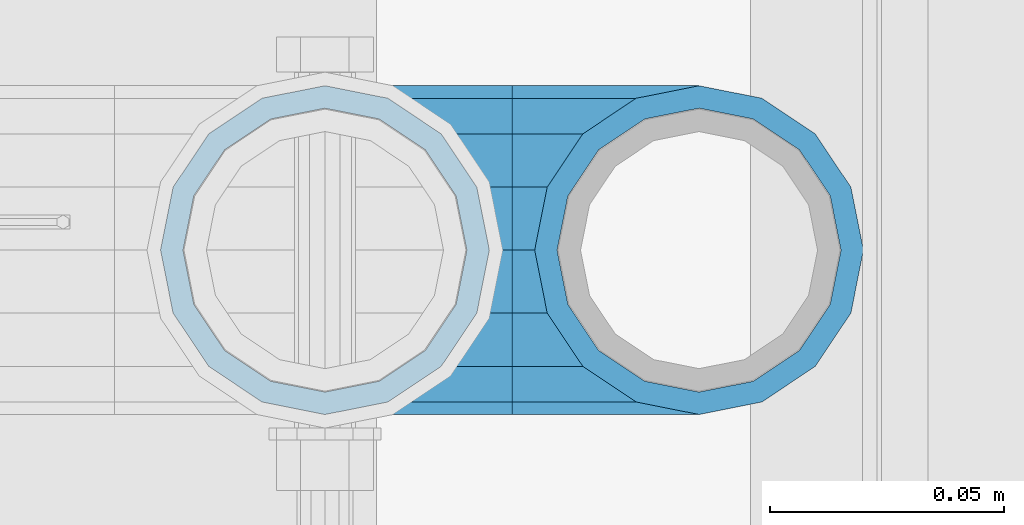
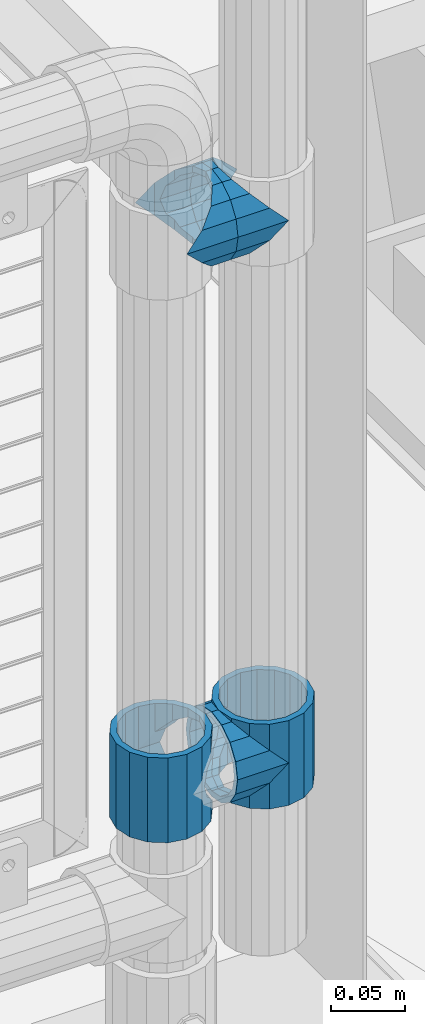
# One storey, part 167 of 242: 5 beams.
"""IFC2X3 building model written with IfcOpenShell, lengths in millimetres."""

from ifc_helpers import new_model, si_unit, frame, origin_with_axes, place, context, subcontext, project, spatial, faceted_brep, material, type_object, element, save


model = new_model("IFC2X3")

# Units and contexts
model_context = context("Model", 3, precision=1e-05, world=origin_with_axes())
body_context = subcontext(model_context, "Body", "Model", "MODEL_VIEW")
ifc_project = project(units=[si_unit("LENGTHUNIT", "METRE", prefix="MILLI"), si_unit("AREAUNIT", "SQUARE_METRE"), si_unit("VOLUMEUNIT", "CUBIC_METRE"), si_unit("MASSUNIT", "GRAM", prefix="KILO"), si_unit("TIMEUNIT", "SECOND"), si_unit("PLANEANGLEUNIT", "RADIAN"), si_unit("SOLIDANGLEUNIT", "STERADIAN"), si_unit("THERMODYNAMICTEMPERATUREUNIT", "DEGREE_CELSIUS"), si_unit("LUMINOUSINTENSITYUNIT", "LUMEN")], contexts=[model_context])

# Site, building, storey
site_placement = place(None, origin_with_axes())
site = spatial("IfcSite", under=ifc_project, at=site_placement, CompositionType="ELEMENT")
building_placement = place(site_placement, origin_with_axes())
building = spatial("IfcBuilding", under=site, at=building_placement, Name="Standard", CompositionType="ELEMENT")
storey_placement = place(building_placement, origin_with_axes())
storey = spatial("IfcBuildingStorey", under=building, at=storey_placement, Name="Undefined", CompositionType="ELEMENT", Elevation=0.0)

# Beams
ifc_material = material(Name="Misc_Undefined")
beam_type = type_object("IfcBeamType", PredefinedType="NOTDEFINED")
beam_1_placement = place(storey_placement, frame((-22576.0, -19335.5, 398.670000000001), z_axis=(0.0, 1.0, 0.0), x_axis=(-1.0, 0.0, 0.0)))
element("IfcBeam", 1, at=beam_1_placement, inside=storey, type_object=beam_type, material=ifc_material, context=body_context, shape_type="Brep", body=[
    faceted_brep([(0.0, 0.0, -35.1500000000015), (13.4513226476338, -13.4513226476329, -32.4743655677703), (13.4513226476338, 13.4513226476329, -32.4743655677703), (32.4743655677739, -26.8123795176754, 13.4513226476338), (32.4743655677739, -32.4743655677717, 13.4513226476338), (24.8548033587067, -24.8548033587072, 24.8548033587067), (24.8548033587067, -16.3810424080019, 24.8548033587067), (27.1226768591077, -21.4606908090117, 21.46069080901), (35.1500000000015, -30.35, 0.0), (35.1500000000015, -35.15, 0.0), (32.8397438117172, -28.0397438117175, 11.614442172282), (32.8397438117099, -28.0397438117175, -11.614442172282), (32.4743655677739, -26.8123795176754, -13.4513226476338), (32.4743655677739, -32.4743655677717, -13.4513226476338), (27.122676859115, -21.4606908090117, -21.46069080901), (24.8548033587067, -16.3810424080019, -24.8548033587067), (24.8548033587067, -24.8548033587072, -24.8548033587067), (20.0882031229849, -11.6144421722805, -28.0397438117179), (16.6306603983758, 0.0, -30.3499999999985), (20.0882031229849, 11.6144421722805, -28.0397438117179), (24.8548033587067, 16.3810424079986, -24.8548033587067), (24.8548033587067, 24.8548033587072, -24.8548033587067), (27.122676859115, 21.4606908090117, -21.46069080901), (32.4743655677739, 26.8123795176776, -13.4513226476338), (32.4743655677739, 32.4743655677717, -13.4513226476338), (32.8397438117099, 28.0397438117175, -11.614442172282), (35.1500000000015, 30.35, 0.0), (35.1500000000015, 35.1499999999996, 0.0), (32.8397438117172, 28.0397438117175, 11.614442172282), (32.4743655677739, 26.8123795176754, 13.4513226476338), (32.4743655677739, 32.4743655677717, 13.4513226476338), (27.1226768591077, 21.4606908090117, 21.46069080901), (24.8548033587067, 16.3810424080019, 24.8548033587067), (24.8548033587067, 24.8548033587072, 24.8548033587067), (13.4513226476338, 13.4513226476329, 32.4743655677703), (13.4513226476338, -13.4513226476329, 32.4743655677703), (0.0, 0.0, 35.1500000000015), (20.0882031229849, 11.6144421722805, 28.0397438117179), (16.6306603983685, 0.0, 30.3499999999985), (20.0882031229849, -11.6144421722805, 28.0397438117179), (40.1500000000015, -35.15, 0.0), (40.1500000000015, -32.4743655677717, 13.4513226476338), (40.1500000000015, -24.8548033587072, 24.8548033587067), (40.1500000000015, -13.4513226476329, 32.4743655677703), (40.1500000000015, 0.0, 35.1500000000015), (40.1500000000015, -24.8548033587072, -24.8548033587067), (40.1500000000015, -32.4743655677717, -13.4513226476338), (40.1500000000015, -13.4513226476329, -32.4743655677703), (40.1500000000015, 0.0, -35.1500000000015), (40.1500000000015, 13.4513226476329, -32.4743655677703), (40.1500000000015, 24.8548033587072, -24.8548033587067), (40.1500000000015, 32.4743655677717, -13.4513226476338), (40.1500000000015, 35.15, 0.0), (40.1500000000015, 32.4743655677717, 13.4513226476338), (40.1500000000015, 24.8548033587072, 24.8548033587067), (40.1500000000015, 13.4513226476329, 32.4743655677703), (40.1500000000015, -21.4606908090117, 21.46069080901), (40.1500000000015, -11.6144421722805, 28.0397438117179), (40.1500000000015, 0.0, 30.3499999999985), (40.1500000000015, 11.6144421722805, 28.0397438117179), (40.1500000000015, 21.4606908090117, 21.46069080901), (40.1500000000015, 28.0397438117175, 11.614442172282), (40.1500000000015, 30.35, 0.0), (40.1500000000015, 28.0397438117175, -11.614442172282), (40.1500000000015, 21.4606908090117, -21.46069080901), (40.1500000000015, 11.6144421722805, -28.0397438117179), (40.1500000000015, 0.0, -30.3499999999985), (40.1500000000015, -11.6144421722805, -28.0397438117179), (40.1500000000015, -21.4606908090117, -21.46069080901), (40.1500000000015, -28.0397438117175, -11.614442172282), (40.1500000000015, -30.35, 0.0), (40.1500000000015, -28.0397438117175, 11.614442172282)], [[[0, 1, 2]], [[3, 4, 5, 6, 7]], [[8, 9, 4, 3, 10]], [[11, 12, 13, 9, 8]], [[14, 15, 16, 13, 12]], [[2, 1, 16, 15, 17, 18, 19, 20, 21]], [[21, 20, 22, 23, 24]], [[24, 23, 25, 26, 27]], [[27, 26, 28, 29, 30]], [[30, 29, 31, 32, 33]], [[34, 35, 36]], [[33, 32, 37, 38, 39, 6, 5, 35, 34]], [[40, 41, 4, 9]], [[41, 42, 5, 4]], [[42, 43, 35, 5]], [[43, 44, 36, 35]], [[45, 46, 13, 16]], [[47, 45, 16, 1]], [[48, 47, 1, 0]], [[49, 48, 0, 2]], [[50, 49, 2, 21]], [[51, 50, 21, 24]], [[52, 51, 24, 27]], [[53, 52, 27, 30]], [[54, 53, 30, 33]], [[55, 54, 33, 34]], [[44, 55, 34, 36]], [[46, 40, 9, 13]], [[45, 47, 48, 49, 50, 51, 52, 53, 54, 55, 44, 43, 42, 41, 40, 46], [56, 57, 58, 59, 60, 61, 62, 63, 64, 65, 66, 67, 68, 69, 70, 71]], [[59, 58, 38, 37]], [[60, 59, 37, 32, 31]], [[61, 60, 31, 29, 28]], [[62, 61, 28, 26]], [[63, 62, 26, 25]], [[22, 64, 63, 25, 23]], [[19, 65, 64, 22, 20]], [[66, 65, 19, 18]], [[67, 66, 18, 17]], [[68, 67, 17, 15, 14]], [[69, 68, 14, 12, 11]], [[70, 69, 11, 8]], [[71, 70, 8, 10]], [[7, 56, 71, 10, 3]], [[39, 57, 56, 7, 6]], [[58, 57, 39, 38]]]),
])
beam_2_placement = place(storey_placement, frame((-22656.0, -19335.5, 433.82), z_axis=(-1.0, 0.0, 0.0), x_axis=(0.0, 0.0, -1.0)))
element("IfcBeam", 2, at=beam_2_placement, inside=storey, type_object=beam_type, material=ifc_material, context=body_context, shape_type="Brep", body=[
    faceted_brep([(7.11025618828211, -11.614442172282, -32.8397438117172), (7.11025618828211, -11.614442172282, -28.0397438117143), (13.6893091909879, -21.46069080901, -21.4606908090136), (13.6893091909879, -21.46069080901, -27.1226768591077), (8.33762048232484, -13.4513226476338, -32.4743655677739), (23.5355578277191, -28.0397438117179, -11.6144421722784), (23.5355578277191, -28.0397438117179, -20.0882031229921), (18.7689575919975, -24.8548033587067, -24.8548033587067), (35.1500000000015, -30.35, 0.0), (35.1499999999996, -30.3499999999985, -16.6306603983758), (46.7644421722801, -28.0397438117179, -11.6144421722784), (46.7644421722801, -28.0397438117179, -20.0882031229921), (51.5310424079973, -24.8548033587067, -24.8548033587067), (56.6106908090114, -21.46069080901, -21.4606908090136), (56.6106908090114, -21.46069080901, -27.1226768591077), (61.9623795176767, -13.4513226476338, -32.4743655677739), (63.1897438117172, -11.614442172282, -28.0397438117143), (63.1897438117172, -11.614442172282, -32.8397438117172), (65.4999999999997, 0.0, -30.3499999999985), (65.4999999999997, 0.0, -35.1500000000015), (63.1897438117172, 11.614442172282, -28.0397438117143), (63.1897438117172, 11.614442172282, -32.8397438117245), (56.6106908090114, 21.46069080901, -21.4606908090136), (56.6106908090114, 21.46069080901, -27.1226768591077), (61.9623795176744, 13.4513226476338, -32.4743655677739), (46.7644421722801, 28.0397438117179, -11.6144421722784), (46.7644421722801, 28.0397438117179, -20.0882031229849), (51.5310424080006, 24.8548033587067, -24.8548033587067), (35.1500000000015, 30.35, 0.0), (35.1499999999996, 30.3499999999985, -16.6306603983685), (23.5355578277192, 28.0397438117179, -11.6144421722784), (23.5355578277192, 28.0397438117179, -20.0882031229849), (18.7689575919987, 24.8548033587067, -24.8548033587067), (13.6893091909879, 21.46069080901, -21.4606908090136), (13.6893091909879, 21.46069080901, -27.1226768591077), (8.33762048232262, 13.4513226476338, -32.4743655677739), (7.11025618828211, 11.614442172282, -28.0397438117143), (7.11025618828211, 11.614442172282, -32.8397438117245), (4.79999999999961, 0.0, -30.3499999999985), (4.79999999999961, 0.0, -35.1500000000015), (0.0, 21.46069080901, 21.4606908090136), (0.0, 28.0397438117179, 11.6144421722784), (70.2999999999993, 28.0397438117179, 11.6144421722784), (70.2999999999993, 21.46069080901, 21.4606908090136), (0.0, 11.614442172282, 28.0397438117143), (70.2999999999993, 11.614442172282, 28.0397438117143), (0.0, 0.0, 30.3499999999985), (70.2999999999993, 0.0, 30.3499999999985), (0.0, -11.614442172282, 28.0397438117143), (70.2999999999993, -11.614442172282, 28.0397438117143), (0.0, -21.46069080901, 21.4606908090136), (70.2999999999993, -21.46069080901, 21.4606908090136), (0.0, -28.0397438117179, 11.6144421722784), (70.2999999999993, -28.0397438117179, 11.6144421722784), (0.0, -24.8548033587067, -24.8548033587067), (0.0, -13.4513226476338, -32.4743655677739), (0.0, 0.0, -35.1500000000015), (0.0, -32.4743655677703, 13.4513226476338), (0.0, -35.1500000000015, 0.0), (70.2999999999993, -35.1500000000015, 0.0), (70.2999999999993, -32.4743655677703, 13.4513226476338), (0.0, -24.8548033587067, 24.8548033587067), (70.2999999999993, -24.8548033587067, 24.8548033587067), (0.0, -13.4513226476338, 32.4743655677739), (70.2999999999993, -13.4513226476338, 32.4743655677739), (0.0, 0.0, 35.1500000000015), (70.2999999999993, 0.0, 35.1500000000015), (0.0, 13.4513226476338, 32.4743655677739), (70.2999999999993, 13.4513226476338, 32.4743655677739), (0.0, 24.8548033587067, 24.8548033587067), (70.2999999999993, 24.8548033587067, 24.8548033587067), (0.0, 32.4743655677703, 13.4513226476338), (70.2999999999993, 32.4743655677703, 13.4513226476338), (0.0, 35.1500000000015, 0.0), (70.2999999999993, 35.1500000000015, 0.0), (0.0, 32.4743655677703, -13.4513226476338), (70.2999999999993, 32.4743655677703, -13.4513226476338), (70.2999999999993, -13.4513226476338, -32.4743655677739), (70.2999999999993, -24.8548033587067, -24.8548033587067), (70.2999999999993, 0.0, -35.1500000000015), (70.2999999999993, 13.4513226476338, -32.4743655677739), (70.2999999999993, 24.8548033587067, -24.8548033587067), (0.0, 24.8548033587067, -24.8548033587067), (0.0, 13.4513226476338, -32.4743655677739), (70.2999999999993, -32.4743655677703, -13.4513226476338), (0.0, -32.4743655677703, -13.4513226476338), (0.0, -28.0397438117179, -11.6144421722784), (0.0, -21.46069080901, -21.4606908090136), (0.0, -11.614442172282, -28.0397438117143), (0.0, 0.0, -30.3499999999985), (0.0, 11.614442172282, -28.0397438117143), (0.0, 21.46069080901, -21.4606908090136), (0.0, 28.0397438117179, -11.6144421722784), (0.0, 30.3499999999985, 0.0), (0.0, -30.3499999999985, 0.0), (70.2999999999993, 30.3499999999985, 0.0), (70.2999999999993, 28.0397438117179, -11.6144421722784), (70.2999999999993, 21.46069080901, -21.4606908090136), (70.2999999999993, 11.614442172282, -28.0397438117143), (70.2999999999993, 0.0, -30.3499999999985), (70.2999999999993, -11.614442172282, -28.0397438117143), (70.2999999999993, -21.46069080901, -21.4606908090136), (70.2999999999993, -28.0397438117179, -11.6144421722784), (70.2999999999993, -30.3499999999985, 0.0)], [[[0, 1, 2, 3, 4]], [[3, 2, 5, 6, 7]], [[6, 5, 8, 9]], [[9, 8, 10, 11]], [[12, 11, 10, 13, 14]], [[15, 14, 13, 16, 17]], [[17, 16, 18, 19]], [[19, 18, 20, 21]], [[21, 20, 22, 23, 24]], [[23, 22, 25, 26, 27]], [[26, 25, 28, 29]], [[29, 28, 30, 31]], [[32, 31, 30, 33, 34]], [[35, 34, 33, 36, 37]], [[37, 36, 38, 39]], [[39, 38, 1, 0]], [[40, 41, 42, 43]], [[44, 40, 43, 45]], [[46, 44, 45, 47]], [[48, 46, 47, 49]], [[50, 48, 49, 51]], [[52, 50, 51, 53]], [[7, 54, 55, 4, 3]], [[4, 55, 56, 39, 0]], [[57, 58, 59, 60]], [[61, 57, 60, 62]], [[63, 61, 62, 64]], [[65, 63, 64, 66]], [[67, 65, 66, 68]], [[69, 67, 68, 70]], [[71, 69, 70, 72]], [[73, 71, 72, 74]], [[75, 73, 74, 76]], [[77, 78, 12, 14, 15]], [[79, 77, 15, 17, 19]], [[24, 80, 79, 19, 21]], [[27, 81, 80, 24, 23]], [[82, 75, 76, 81, 27, 26, 29, 31, 32]], [[83, 82, 32, 34, 35]], [[56, 83, 35, 37, 39]], [[9, 11, 12, 78, 84, 85, 54, 7, 6]], [[58, 85, 84, 59]], [[57, 61, 63, 65, 67, 69, 71, 73, 75, 82, 83, 56, 55, 54, 85, 58], [86, 87, 88, 89, 90, 91, 92, 93, 41, 40, 44, 46, 48, 50, 52, 94]], [[90, 89, 38, 36]], [[91, 90, 36, 33]], [[92, 91, 33, 30]], [[93, 92, 30, 28]], [[41, 93, 28, 95, 42]], [[96, 95, 28, 25]], [[97, 96, 25, 22]], [[98, 97, 22, 20]], [[99, 98, 20, 18]], [[100, 99, 18, 16]], [[101, 100, 16, 13]], [[102, 101, 13, 10]], [[103, 102, 10, 8]], [[78, 77, 79, 80, 81, 76, 74, 72, 70, 68, 66, 64, 62, 60, 59, 84], [51, 49, 47, 45, 43, 42, 95, 96, 97, 98, 99, 100, 101, 102, 103, 53]], [[8, 94, 52, 53, 103]], [[86, 94, 8, 5]], [[87, 86, 5, 2]], [[88, 87, 2, 1]], [[89, 88, 1, 38]]]),
])
beam_3_placement = place(storey_placement, frame((-22576.0, -19335.5, 433.82), z_axis=(1.0, 0.0, 0.0), x_axis=(0.0, 0.0, -1.0)))
element("IfcBeam", 3, at=beam_3_placement, inside=storey, type_object=beam_type, material=ifc_material, context=body_context, shape_type="Brep", body=[
    faceted_brep([(56.6106908090114, 21.46069080901, -27.1226768591077), (56.6106908090114, 21.46069080901, -21.4606908090136), (46.7644421722801, 28.0397438117179, -11.6144421722784), (46.7644421722801, 28.0397438117179, -20.0882031229849), (51.5310424080006, 24.8548033587067, -24.8548033587067), (63.1897438117172, 11.614442172282, -32.8397438117245), (63.1897438117172, 11.614442172282, -28.0397438117143), (61.9623795176744, 13.4513226476338, -32.4743655677739), (65.4999999999997, 0.0, -35.1500000000015), (65.4999999999997, 0.0, -30.3499999999985), (63.1897438117172, -11.614442172282, -32.8397438117172), (63.1897438117172, -11.614442172282, -28.0397438117143), (61.9623795176767, -13.4513226476338, -32.4743655677739), (56.6106908090114, -21.46069080901, -27.1226768591077), (56.6106908090114, -21.46069080901, -21.4606908090136), (51.5310424079973, -24.8548033587067, -24.8548033587067), (46.7644421722801, -28.0397438117179, -20.0882031229921), (46.7644421722801, -28.0397438117179, -11.6144421722784), (35.1499999999996, -30.3499999999985, -16.6306603983758), (35.1500000000015, -30.35, 0.0), (23.5355578277191, -28.0397438117179, -20.0882031229921), (23.5355578277191, -28.0397438117179, -11.6144421722784), (13.6893091909879, -21.46069080901, -27.1226768591077), (13.6893091909879, -21.46069080901, -21.4606908090136), (18.7689575919975, -24.8548033587067, -24.8548033587067), (7.11025618828211, -11.614442172282, -32.8397438117172), (7.11025618828211, -11.614442172282, -28.0397438117143), (8.33762048232484, -13.4513226476338, -32.4743655677739), (4.79999999999961, 0.0, -35.1500000000015), (4.79999999999961, 0.0, -30.3499999999985), (7.11025618828211, 11.614442172282, -32.8397438117245), (7.11025618828211, 11.614442172282, -28.0397438117143), (8.33762048232262, 13.4513226476338, -32.4743655677739), (13.6893091909879, 21.46069080901, -27.1226768591077), (13.6893091909879, 21.46069080901, -21.4606908090136), (18.7689575919987, 24.8548033587067, -24.8548033587067), (23.5355578277192, 28.0397438117179, -20.0882031229849), (23.5355578277192, 28.0397438117179, -11.6144421722784), (35.1499999999996, 30.3499999999985, -16.6306603983685), (35.1500000000015, 30.35, 0.0), (0.0, 32.4743655677703, -13.4513226476338), (0.0, 35.1500000000015, 0.0), (70.2999999999993, 35.1500000000015, 0.0), (70.2999999999993, 32.4743655677703, -13.4513226476338), (0.0, 32.4743655677703, 13.4513226476338), (70.2999999999993, 32.4743655677703, 13.4513226476338), (0.0, 24.8548033587067, 24.8548033587067), (70.2999999999993, 24.8548033587067, 24.8548033587067), (0.0, 13.4513226476338, 32.4743655677739), (70.2999999999993, 13.4513226476338, 32.4743655677739), (0.0, 0.0, 35.1500000000015), (70.2999999999993, 0.0, 35.1500000000015), (0.0, -13.4513226476338, 32.4743655677739), (70.2999999999993, -13.4513226476338, 32.4743655677739), (0.0, -24.8548033587067, 24.8548033587067), (70.2999999999993, -24.8548033587067, 24.8548033587067), (0.0, -32.4743655677703, 13.4513226476338), (70.2999999999993, -32.4743655677703, 13.4513226476338), (0.0, -35.1500000000015, 0.0), (70.2999999999993, -35.1500000000015, 0.0), (70.2999999999993, -30.3499999999985, 0.0), (70.2999999999993, -28.0397438117179, -11.6144421722784), (70.2999999999993, -21.46069080901, -21.4606908090136), (70.2999999999993, -11.614442172282, -28.0397438117143), (70.2999999999993, 0.0, -30.3499999999985), (70.2999999999993, 11.614442172282, -28.0397438117143), (70.2999999999993, 21.46069080901, -21.4606908090136), (70.2999999999993, 28.0397438117179, -11.6144421722784), (0.0, -28.0397438117179, -11.6144421722784), (0.0, -30.3499999999985, 0.0), (0.0, -21.46069080901, -21.4606908090136), (0.0, -11.614442172282, -28.0397438117143), (0.0, 0.0, -30.3499999999985), (0.0, 11.614442172282, -28.0397438117143), (0.0, 21.46069080901, -21.4606908090136), (0.0, 28.0397438117179, -11.6144421722784), (0.0, 30.3499999999985, 0.0), (70.2999999999993, 30.3499999999985, 0.0), (0.0, 28.0397438117179, 11.6144421722784), (70.2999999999993, 28.0397438117179, 11.6144421722784), (0.0, 21.46069080901, 21.4606908090136), (70.2999999999993, 21.46069080901, 21.4606908090136), (0.0, 11.614442172282, 28.0397438117143), (70.2999999999993, 11.614442172282, 28.0397438117143), (0.0, 0.0, 30.3499999999985), (70.2999999999993, 0.0, 30.3499999999985), (0.0, -11.614442172282, 28.0397438117143), (70.2999999999993, -11.614442172282, 28.0397438117143), (0.0, -21.46069080901, 21.4606908090136), (70.2999999999993, -21.46069080901, 21.4606908090136), (0.0, -28.0397438117179, 11.6144421722784), (70.2999999999993, -28.0397438117179, 11.6144421722784), (70.2999999999993, -24.8548033587067, -24.8548033587067), (70.2999999999993, -13.4513226476338, -32.4743655677739), (70.2999999999993, 0.0, -35.1500000000015), (70.2999999999993, 13.4513226476338, -32.4743655677739), (70.2999999999993, 24.8548033587067, -24.8548033587067), (70.2999999999993, -32.4743655677703, -13.4513226476338), (0.0, -32.4743655677703, -13.4513226476338), (0.0, 24.8548033587067, -24.8548033587067), (0.0, 13.4513226476338, -32.4743655677739), (0.0, 0.0, -35.1500000000015), (0.0, -13.4513226476338, -32.4743655677739), (0.0, -24.8548033587067, -24.8548033587067)], [[[0, 1, 2, 3, 4]], [[5, 6, 1, 0, 7]], [[8, 9, 6, 5]], [[10, 11, 9, 8]], [[12, 13, 14, 11, 10]], [[15, 16, 17, 14, 13]], [[18, 19, 17, 16]], [[20, 21, 19, 18]], [[22, 23, 21, 20, 24]], [[25, 26, 23, 22, 27]], [[28, 29, 26, 25]], [[30, 31, 29, 28]], [[32, 33, 34, 31, 30]], [[35, 36, 37, 34, 33]], [[38, 39, 37, 36]], [[3, 2, 39, 38]], [[40, 41, 42, 43]], [[41, 44, 45, 42]], [[44, 46, 47, 45]], [[46, 48, 49, 47]], [[48, 50, 51, 49]], [[50, 52, 53, 51]], [[52, 54, 55, 53]], [[54, 56, 57, 55]], [[56, 58, 59, 57]], [[60, 61, 17, 19]], [[61, 62, 14, 17]], [[62, 63, 11, 14]], [[63, 64, 9, 11]], [[64, 65, 6, 9]], [[65, 66, 1, 6]], [[66, 67, 2, 1]], [[68, 69, 19, 21]], [[70, 68, 21, 23]], [[71, 70, 23, 26]], [[72, 71, 26, 29]], [[73, 72, 29, 31]], [[74, 73, 31, 34]], [[75, 74, 34, 37]], [[76, 75, 37, 39]], [[67, 77, 39, 2]], [[78, 76, 39, 77, 79]], [[80, 78, 79, 81]], [[82, 80, 81, 83]], [[84, 82, 83, 85]], [[86, 84, 85, 87]], [[88, 86, 87, 89]], [[90, 88, 89, 91]], [[19, 69, 90, 91, 60]], [[92, 93, 94, 95, 96, 43, 42, 45, 47, 49, 51, 53, 55, 57, 59, 97], [89, 87, 85, 83, 81, 79, 77, 67, 66, 65, 64, 63, 62, 61, 60, 91]], [[58, 98, 97, 59]], [[56, 54, 52, 50, 48, 46, 44, 41, 40, 99, 100, 101, 102, 103, 98, 58], [68, 70, 71, 72, 73, 74, 75, 76, 78, 80, 82, 84, 86, 88, 90, 69]], [[100, 99, 35, 33, 32]], [[101, 100, 32, 30, 28]], [[27, 102, 101, 28, 25]], [[24, 103, 102, 27, 22]], [[18, 16, 15, 92, 97, 98, 103, 24, 20]], [[93, 92, 15, 13, 12]], [[94, 93, 12, 10, 8]], [[7, 95, 94, 8, 5]], [[4, 96, 95, 7, 0]], [[99, 40, 43, 96, 4, 3, 38, 36, 35]]]),
])
beam_4_placement = place(storey_placement, frame((-22656.0, -19335.5, 848.670000000001), z_axis=(0.0, -1.0, 0.0), x_axis=(1.0, 0.0, 0.0)))
element("IfcBeam", 4, at=beam_4_placement, inside=storey, type_object=beam_type, material=ifc_material, context=body_context, shape_type="Brep", body=[
    faceted_brep([(0.0, 0.0, -35.1500000000015), (13.4513226476338, -13.4513226476329, -32.4743655677703), (13.4513226476338, 13.4513226476329, -32.4743655677703), (32.4743655677739, 32.4743655677717, 13.4513226476338), (32.4743655677739, 26.8123795176754, 13.4513226476338), (27.1226768591077, 21.4606908090117, 21.46069080901), (24.8548033587067, 16.3810424080019, 24.8548033587067), (24.8548033587067, 24.8548033587072, 24.8548033587067), (13.4513226476338, 13.4513226476329, 32.4743655677703), (13.4513226476338, -13.4513226476329, 32.4743655677703), (0.0, 0.0, 35.1500000000015), (20.0882031229849, 11.6144421722805, 28.0397438117179), (16.6306603983685, 0.0, 30.3499999999985), (20.0882031229849, -11.6144421722805, 28.0397438117179), (24.8548033587067, -16.3810424080019, 24.8548033587067), (24.8548033587067, -24.8548033587072, 24.8548033587067), (32.4743655677739, -26.8123795176754, 13.4513226476338), (32.4743655677739, -32.4743655677717, 13.4513226476338), (27.1226768591077, -21.4606908090117, 21.46069080901), (35.1500000000015, -30.35, 0.0), (35.1500000000015, -35.15, 0.0), (32.8397438117172, -28.0397438117175, 11.614442172282), (32.8397438117099, -28.0397438117175, -11.614442172282), (32.4743655677739, -26.8123795176754, -13.4513226476338), (32.4743655677739, -32.4743655677717, -13.4513226476338), (27.122676859115, -21.4606908090117, -21.46069080901), (24.8548033587067, -16.3810424080019, -24.8548033587067), (24.8548033587067, -24.8548033587072, -24.8548033587067), (20.0882031229849, -11.6144421722805, -28.0397438117179), (16.6306603983758, 0.0, -30.3499999999985), (20.0882031229849, 11.6144421722805, -28.0397438117179), (24.8548033587067, 16.3810424079986, -24.8548033587067), (24.8548033587067, 24.8548033587072, -24.8548033587067), (27.122676859115, 21.4606908090117, -21.46069080901), (32.4743655677739, 26.8123795176776, -13.4513226476338), (32.4743655677739, 32.4743655677717, -13.4513226476338), (32.8397438117099, 28.0397438117175, -11.614442172282), (35.1500000000015, 30.35, 0.0), (35.1500000000015, 35.1499999999996, 0.0), (32.8397438117172, 28.0397438117175, 11.614442172282), (40.1500000000015, -35.15, 0.0), (40.1500000000015, -32.4743655677717, 13.4513226476338), (40.1500000000015, -24.8548033587072, 24.8548033587067), (40.1500000000015, -13.4513226476329, 32.4743655677703), (40.1500000000015, 0.0, 35.1500000000015), (40.1500000000015, 13.4513226476329, 32.4743655677703), (40.1500000000015, 24.8548033587072, 24.8548033587067), (40.1500000000015, 32.4743655677717, 13.4513226476338), (40.1500000000015, 35.15, 0.0), (40.1500000000015, -24.8548033587072, -24.8548033587067), (40.1500000000015, -32.4743655677717, -13.4513226476338), (40.1500000000015, -13.4513226476329, -32.4743655677703), (40.1500000000015, 0.0, -35.1500000000015), (40.1500000000015, 13.4513226476329, -32.4743655677703), (40.1500000000015, 24.8548033587072, -24.8548033587067), (40.1500000000015, 32.4743655677717, -13.4513226476338), (40.1500000000015, -21.4606908090117, 21.46069080901), (40.1500000000015, -11.6144421722805, 28.0397438117179), (40.1500000000015, 0.0, 30.3499999999985), (40.1500000000015, 11.6144421722805, 28.0397438117179), (40.1500000000015, 21.4606908090117, 21.46069080901), (40.1500000000015, 28.0397438117175, 11.614442172282), (40.1500000000015, 30.35, 0.0), (40.1500000000015, 28.0397438117175, -11.614442172282), (40.1500000000015, 21.4606908090117, -21.46069080901), (40.1500000000015, 11.6144421722805, -28.0397438117179), (40.1500000000015, 0.0, -30.3499999999985), (40.1500000000015, -11.6144421722805, -28.0397438117179), (40.1500000000015, -21.4606908090117, -21.46069080901), (40.1500000000015, -28.0397438117175, -11.614442172282), (40.1500000000015, -30.35, 0.0), (40.1500000000015, -28.0397438117175, 11.614442172282)], [[[0, 1, 2]], [[3, 4, 5, 6, 7]], [[8, 9, 10]], [[7, 6, 11, 12, 13, 14, 15, 9, 8]], [[16, 17, 15, 14, 18]], [[19, 20, 17, 16, 21]], [[22, 23, 24, 20, 19]], [[25, 26, 27, 24, 23]], [[2, 1, 27, 26, 28, 29, 30, 31, 32]], [[32, 31, 33, 34, 35]], [[35, 34, 36, 37, 38]], [[38, 37, 39, 4, 3]], [[40, 41, 17, 20]], [[41, 42, 15, 17]], [[42, 43, 9, 15]], [[43, 44, 10, 9]], [[44, 45, 8, 10]], [[45, 46, 7, 8]], [[46, 47, 3, 7]], [[47, 48, 38, 3]], [[49, 50, 24, 27]], [[51, 49, 27, 1]], [[52, 51, 1, 0]], [[53, 52, 0, 2]], [[54, 53, 2, 32]], [[55, 54, 32, 35]], [[48, 55, 35, 38]], [[50, 40, 20, 24]], [[49, 51, 52, 53, 54, 55, 48, 47, 46, 45, 44, 43, 42, 41, 40, 50], [56, 57, 58, 59, 60, 61, 62, 63, 64, 65, 66, 67, 68, 69, 70, 71]], [[63, 62, 37, 36]], [[33, 64, 63, 36, 34]], [[30, 65, 64, 33, 31]], [[66, 65, 30, 29]], [[67, 66, 29, 28]], [[68, 67, 28, 26, 25]], [[69, 68, 25, 23, 22]], [[70, 69, 22, 19]], [[71, 70, 19, 21]], [[18, 56, 71, 21, 16]], [[13, 57, 56, 18, 14]], [[58, 57, 13, 12]], [[59, 58, 12, 11]], [[60, 59, 11, 6, 5]], [[61, 60, 5, 4, 39]], [[62, 61, 39, 37]]]),
])
beam_5_placement = place(storey_placement, frame((-22576.0, -19335.5, 848.670000000001), z_axis=(0.0, 1.0, 0.0), x_axis=(-1.0, 0.0, 0.0)))
element("IfcBeam", 5, at=beam_5_placement, inside=storey, type_object=beam_type, material=ifc_material, context=body_context, shape_type="Brep", body=[
    faceted_brep([(0.0, 0.0, -35.1500000000015), (13.4513226476338, -13.4513226476329, -32.4743655677703), (13.4513226476338, 13.4513226476329, -32.4743655677703), (32.4743655677739, -26.8123795176754, 13.4513226476338), (32.4743655677739, -32.4743655677717, 13.4513226476338), (24.8548033587067, -24.8548033587072, 24.8548033587067), (24.8548033587067, -16.3810424080019, 24.8548033587067), (27.1226768591077, -21.4606908090117, 21.46069080901), (35.1500000000015, -30.35, 0.0), (35.1500000000015, -35.15, 0.0), (32.8397438117172, -28.0397438117175, 11.614442172282), (32.8397438117099, -28.0397438117175, -11.614442172282), (32.4743655677739, -26.8123795176754, -13.4513226476338), (32.4743655677739, -32.4743655677717, -13.4513226476338), (27.122676859115, -21.4606908090117, -21.46069080901), (24.8548033587067, -16.3810424080019, -24.8548033587067), (24.8548033587067, -24.8548033587072, -24.8548033587067), (20.0882031229849, -11.6144421722805, -28.0397438117179), (16.6306603983758, 0.0, -30.3499999999985), (20.0882031229849, 11.6144421722805, -28.0397438117179), (24.8548033587067, 16.3810424079986, -24.8548033587067), (24.8548033587067, 24.8548033587072, -24.8548033587067), (27.122676859115, 21.4606908090117, -21.46069080901), (32.4743655677739, 26.8123795176776, -13.4513226476338), (32.4743655677739, 32.4743655677717, -13.4513226476338), (32.8397438117099, 28.0397438117175, -11.614442172282), (35.1500000000015, 30.35, 0.0), (35.1500000000015, 35.1499999999996, 0.0), (32.8397438117172, 28.0397438117175, 11.614442172282), (32.4743655677739, 26.8123795176754, 13.4513226476338), (32.4743655677739, 32.4743655677717, 13.4513226476338), (27.1226768591077, 21.4606908090117, 21.46069080901), (24.8548033587067, 16.3810424080019, 24.8548033587067), (24.8548033587067, 24.8548033587072, 24.8548033587067), (13.4513226476338, 13.4513226476329, 32.4743655677703), (13.4513226476338, -13.4513226476329, 32.4743655677703), (0.0, 0.0, 35.1500000000015), (20.0882031229849, 11.6144421722805, 28.0397438117179), (16.6306603983685, 0.0, 30.3499999999985), (20.0882031229849, -11.6144421722805, 28.0397438117179), (40.1500000000015, -35.15, 0.0), (40.1500000000015, -32.4743655677717, 13.4513226476338), (40.1500000000015, -24.8548033587072, 24.8548033587067), (40.1500000000015, -13.4513226476329, 32.4743655677703), (40.1500000000015, 0.0, 35.1500000000015), (40.1500000000015, -24.8548033587072, -24.8548033587067), (40.1500000000015, -32.4743655677717, -13.4513226476338), (40.1500000000015, -13.4513226476329, -32.4743655677703), (40.1500000000015, 0.0, -35.1500000000015), (40.1500000000015, 13.4513226476329, -32.4743655677703), (40.1500000000015, 24.8548033587072, -24.8548033587067), (40.1500000000015, 32.4743655677717, -13.4513226476338), (40.1500000000015, 35.15, 0.0), (40.1500000000015, 32.4743655677717, 13.4513226476338), (40.1500000000015, 24.8548033587072, 24.8548033587067), (40.1500000000015, 13.4513226476329, 32.4743655677703), (40.1500000000015, -21.4606908090117, 21.46069080901), (40.1500000000015, -11.6144421722805, 28.0397438117179), (40.1500000000015, 0.0, 30.3499999999985), (40.1500000000015, 11.6144421722805, 28.0397438117179), (40.1500000000015, 21.4606908090117, 21.46069080901), (40.1500000000015, 28.0397438117175, 11.614442172282), (40.1500000000015, 30.35, 0.0), (40.1500000000015, 28.0397438117175, -11.614442172282), (40.1500000000015, 21.4606908090117, -21.46069080901), (40.1500000000015, 11.6144421722805, -28.0397438117179), (40.1500000000015, 0.0, -30.3499999999985), (40.1500000000015, -11.6144421722805, -28.0397438117179), (40.1500000000015, -21.4606908090117, -21.46069080901), (40.1500000000015, -28.0397438117175, -11.614442172282), (40.1500000000015, -30.35, 0.0), (40.1500000000015, -28.0397438117175, 11.614442172282)], [[[0, 1, 2]], [[3, 4, 5, 6, 7]], [[8, 9, 4, 3, 10]], [[11, 12, 13, 9, 8]], [[14, 15, 16, 13, 12]], [[2, 1, 16, 15, 17, 18, 19, 20, 21]], [[21, 20, 22, 23, 24]], [[24, 23, 25, 26, 27]], [[27, 26, 28, 29, 30]], [[30, 29, 31, 32, 33]], [[34, 35, 36]], [[33, 32, 37, 38, 39, 6, 5, 35, 34]], [[40, 41, 4, 9]], [[41, 42, 5, 4]], [[42, 43, 35, 5]], [[43, 44, 36, 35]], [[45, 46, 13, 16]], [[47, 45, 16, 1]], [[48, 47, 1, 0]], [[49, 48, 0, 2]], [[50, 49, 2, 21]], [[51, 50, 21, 24]], [[52, 51, 24, 27]], [[53, 52, 27, 30]], [[54, 53, 30, 33]], [[55, 54, 33, 34]], [[44, 55, 34, 36]], [[46, 40, 9, 13]], [[45, 47, 48, 49, 50, 51, 52, 53, 54, 55, 44, 43, 42, 41, 40, 46], [56, 57, 58, 59, 60, 61, 62, 63, 64, 65, 66, 67, 68, 69, 70, 71]], [[59, 58, 38, 37]], [[60, 59, 37, 32, 31]], [[61, 60, 31, 29, 28]], [[62, 61, 28, 26]], [[63, 62, 26, 25]], [[22, 64, 63, 25, 23]], [[19, 65, 64, 22, 20]], [[66, 65, 19, 18]], [[67, 66, 18, 17]], [[68, 67, 17, 15, 14]], [[69, 68, 14, 12, 11]], [[70, 69, 11, 8]], [[71, 70, 8, 10]], [[7, 56, 71, 10, 3]], [[39, 57, 56, 7, 6]], [[58, 57, 39, 38]]]),
])

save(model, "model.ifc")
